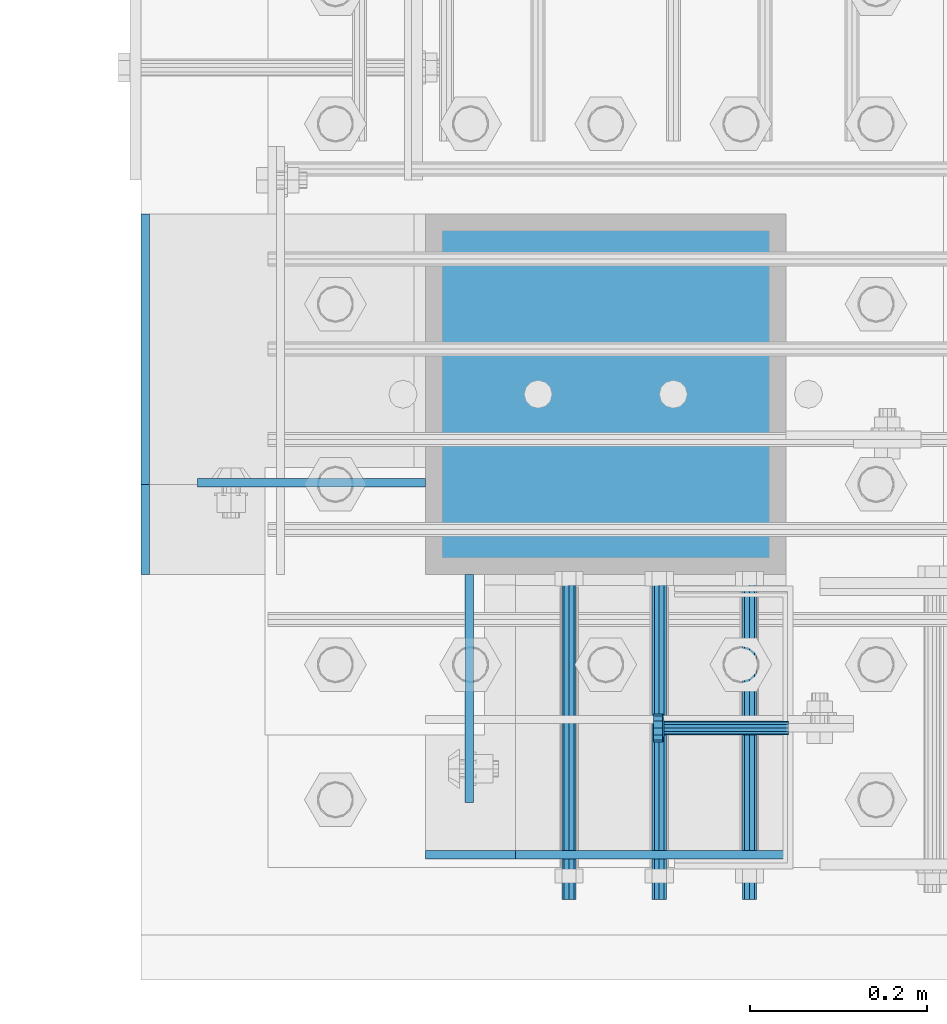
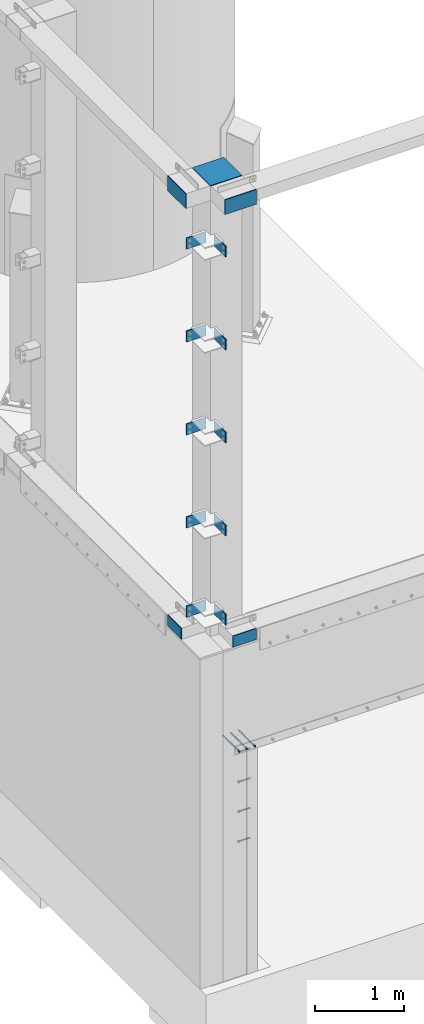
# One storey, part 1080 of 1876: 22 beams, 5 elements without a shape of their own.
"""IFC2X3 building model written with IfcOpenShell, lengths in millimetres."""

from ifc_helpers import new_model, si_unit, frame, origin_with_axes, place, context, subcontext, project, spatial, faceted_brep, material, type_object, element, aggregate, save


model = new_model("IFC2X3")

# Units and contexts
model_context = context("Model", 3, precision=1e-05, world=origin_with_axes())
body_context = subcontext(model_context, "Body", "Model", "MODEL_VIEW")
ifc_project = project(units=[si_unit("LENGTHUNIT", "METRE", prefix="MILLI"), si_unit("AREAUNIT", "SQUARE_METRE"), si_unit("VOLUMEUNIT", "CUBIC_METRE"), si_unit("MASSUNIT", "GRAM", prefix="KILO"), si_unit("TIMEUNIT", "SECOND"), si_unit("PLANEANGLEUNIT", "RADIAN"), si_unit("SOLIDANGLEUNIT", "STERADIAN"), si_unit("THERMODYNAMICTEMPERATUREUNIT", "DEGREE_CELSIUS"), si_unit("LUMINOUSINTENSITYUNIT", "LUMEN")], contexts=[model_context])

# Site, building, storey
site_placement = place(None, origin_with_axes())
site = spatial("IfcSite", under=ifc_project, at=site_placement, CompositionType="ELEMENT")
building_placement = place(site_placement, origin_with_axes())
building = spatial("IfcBuilding", under=site, at=building_placement, Name="Undefined", CompositionType="ELEMENT")
storey_placement = place(building_placement, origin_with_axes())
storey = spatial("IfcBuildingStorey", under=building, at=storey_placement, Name="Undefined", CompositionType="ELEMENT", Elevation=0.0)

# Assembly, beams
assembly_1_placement = place(storey_placement, origin_with_axes())
assembly_1 = element("IfcElementAssembly", 1, at=assembly_1_placement, inside=storey, Name="COLUMN", AssemblyPlace="NOTDEFINED", PredefinedType="RIGID_FRAME")
ifc_material_1 = material(Name="STEEL/A36")
beam_type_1 = type_object("IfcBeamType", PredefinedType="NOTDEFINED")
beam_1_placement = place(assembly_1_placement, frame((77.7874999999989, -25603.2, 4878.3875), z_axis=(0.0, 0.0, -1.0), x_axis=(0.0, -1.0, 0.0)))
beam_1 = element("IfcBeam", 2, at=beam_1_placement, type_object=beam_type_1, material=ifc_material_1, Name="PLATE", context=body_context, shape_type="Brep", body=[
    faceted_brep([(0.0, 4.76249999999982, -76.1999999999998), (3.63797880709171e-12, 4.76249999999982, 76.1999969482422), (257.174999999999, 4.76249999999982, 76.1999999999998), (257.174999999999, 4.76249999999982, -76.1999999999998), (3.63797880709171e-12, -4.76249999999982, 76.1999969482422), (257.174999999999, -4.76249999999982, 76.1999999999998), (0.0, -4.76249999999982, -76.1999999999998), (257.174999999999, -4.76249999999982, -76.1999999999998)], [[[0, 1, 2, 3]], [[1, 4, 5, 2]], [[4, 6, 7, 5]], [[6, 0, 3, 7]], [[5, 7, 3, 2]], [[6, 4, 1, 0]]]),
])
beam_2_placement = place(assembly_1_placement, frame((28.5750000000013, -25500.0124984741, 4878.38749999999), z_axis=(0.0, 0.0, -1.0), x_axis=(-1.0, 0.0, 0.0)))
beam_2 = element("IfcBeam", 3, at=beam_2_placement, type_object=beam_type_1, material=ifc_material_1, Name="PLATE", context=body_context, shape_type="Brep", body=[
    faceted_brep([(0.0, 4.76249999999982, -76.1999999999998), (3.63797880709171e-12, 4.76249999999982, 76.1999969482422), (257.174999999999, 4.76249999999982, 76.1999999999998), (257.174999999999, 4.76249999999982, -76.1999999999998), (3.63797880709171e-12, -4.76249999999982, 76.1999969482422), (257.174999999999, -4.76249999999982, 76.1999999999998), (0.0, -4.76249999999982, -76.1999999999998), (257.174999999999, -4.76249999999982, -76.1999999999998)], [[[0, 1, 2, 3]], [[1, 4, 5, 2]], [[4, 6, 7, 5]], [[6, 0, 3, 7]], [[5, 7, 3, 2]], [[6, 4, 1, 0]]]),
])
beam_3_placement = place(assembly_1_placement, frame((77.787499999998, -25603.2, 9904.41249999999), z_axis=(0.0, 0.0, -1.0), x_axis=(0.0, -1.0, 0.0)))
beam_3 = element("IfcBeam", 4, at=beam_3_placement, type_object=beam_type_1, material=ifc_material_1, Name="PLATE", context=body_context, shape_type="Brep", body=[
    faceted_brep([(0.0, 4.76249999999982, -76.1999999999998), (3.63797880709171e-12, 4.76249999999982, 76.1999969482422), (257.174999999999, 4.76249999999982, 76.1999999999998), (257.174999999999, 4.76249999999982, -76.1999999999998), (3.63797880709171e-12, -4.76249999999982, 76.1999969482422), (257.174999999999, -4.76249999999982, 76.1999999999998), (0.0, -4.76249999999982, -76.1999999999998), (257.174999999999, -4.76249999999982, -76.1999999999998)], [[[0, 1, 2, 3]], [[1, 4, 5, 2]], [[4, 6, 7, 5]], [[6, 0, 3, 7]], [[5, 7, 3, 2]], [[6, 4, 1, 0]]]),
])
beam_4_placement = place(assembly_1_placement, frame((77.7874999999989, -25603.2, 8635.47083333333), z_axis=(0.0, 0.0, -1.0), x_axis=(0.0, -1.0, 0.0)))
beam_4 = element("IfcBeam", 5, at=beam_4_placement, type_object=beam_type_1, material=ifc_material_1, Name="PLATE", context=body_context, shape_type="Brep", body=[
    faceted_brep([(0.0, 4.76249999999982, -76.1999999999998), (3.63797880709171e-12, 4.76249999999982, 76.1999969482422), (257.174999999999, 4.76249999999982, 76.1999999999998), (257.174999999999, 4.76249999999982, -76.1999999999998), (3.63797880709171e-12, -4.76249999999982, 76.1999969482422), (257.174999999999, -4.76249999999982, 76.1999999999998), (0.0, -4.76249999999982, -76.1999999999998), (257.174999999999, -4.76249999999982, -76.1999999999998)], [[[0, 1, 2, 3]], [[1, 4, 5, 2]], [[4, 6, 7, 5]], [[6, 0, 3, 7]], [[5, 7, 3, 2]], [[6, 4, 1, 0]]]),
])
beam_5_placement = place(assembly_1_placement, frame((77.7874999999989, -25603.2, 7366.52916666666), z_axis=(0.0, 0.0, -1.0), x_axis=(0.0, -1.0, 0.0)))
beam_5 = element("IfcBeam", 6, at=beam_5_placement, type_object=beam_type_1, material=ifc_material_1, Name="PLATE", context=body_context, shape_type="Brep", body=[
    faceted_brep([(0.0, 4.76249999999982, -76.1999999999998), (3.63797880709171e-12, 4.76249999999982, 76.1999969482422), (257.174999999999, 4.76249999999982, 76.1999999999998), (257.174999999999, 4.76249999999982, -76.1999999999998), (3.63797880709171e-12, -4.76249999999982, 76.1999969482422), (257.174999999999, -4.76249999999982, 76.1999999999998), (0.0, -4.76249999999982, -76.1999999999998), (257.174999999999, -4.76249999999982, -76.1999999999998)], [[[0, 1, 2, 3]], [[1, 4, 5, 2]], [[4, 6, 7, 5]], [[6, 0, 3, 7]], [[5, 7, 3, 2]], [[6, 4, 1, 0]]]),
])
beam_6_placement = place(assembly_1_placement, frame((77.7874999999989, -25603.2, 6097.5875), z_axis=(0.0, 0.0, -1.0), x_axis=(0.0, -1.0, 0.0)))
beam_6 = element("IfcBeam", 7, at=beam_6_placement, type_object=beam_type_1, material=ifc_material_1, Name="PLATE", context=body_context, shape_type="Brep", body=[
    faceted_brep([(0.0, 4.76249999999982, -76.1999999999998), (3.63797880709171e-12, 4.76249999999982, 76.1999969482422), (257.174999999999, 4.76249999999982, 76.1999999999998), (257.174999999999, 4.76249999999982, -76.1999999999998), (3.63797880709171e-12, -4.76249999999982, 76.1999969482422), (257.174999999999, -4.76249999999982, 76.1999999999998), (0.0, -4.76249999999982, -76.1999999999998), (257.174999999999, -4.76249999999982, -76.1999999999998)], [[[0, 1, 2, 3]], [[1, 4, 5, 2]], [[4, 6, 7, 5]], [[6, 0, 3, 7]], [[5, 7, 3, 2]], [[6, 4, 1, 0]]]),
])
beam_7_placement = place(assembly_1_placement, frame((28.5750000000013, -25500.0124984741, 9904.41249999999), z_axis=(0.0, 0.0, -1.0), x_axis=(-1.0, 0.0, 0.0)))
beam_7 = element("IfcBeam", 8, at=beam_7_placement, type_object=beam_type_1, material=ifc_material_1, Name="PLATE", context=body_context, shape_type="Brep", body=[
    faceted_brep([(0.0, 4.76249999999982, -76.1999999999998), (3.63797880709171e-12, 4.76249999999982, 76.1999969482422), (257.174999999999, 4.76249999999982, 76.1999999999998), (257.174999999999, 4.76249999999982, -76.1999999999998), (3.63797880709171e-12, -4.76249999999982, 76.1999969482422), (257.174999999999, -4.76249999999982, 76.1999999999998), (0.0, -4.76249999999982, -76.1999999999998), (257.174999999999, -4.76249999999982, -76.1999999999998)], [[[0, 1, 2, 3]], [[1, 4, 5, 2]], [[4, 6, 7, 5]], [[6, 0, 3, 7]], [[5, 7, 3, 2]], [[6, 4, 1, 0]]]),
])
beam_8_placement = place(assembly_1_placement, frame((28.5750000000013, -25500.0124984741, 8635.47083333333), z_axis=(0.0, 0.0, -1.0), x_axis=(-1.0, 0.0, 0.0)))
beam_8 = element("IfcBeam", 9, at=beam_8_placement, type_object=beam_type_1, material=ifc_material_1, Name="PLATE", context=body_context, shape_type="Brep", body=[
    faceted_brep([(0.0, 4.76249999999982, -76.1999999999998), (3.63797880709171e-12, 4.76249999999982, 76.1999969482422), (257.174999999999, 4.76249999999982, 76.1999999999998), (257.174999999999, 4.76249999999982, -76.1999999999998), (3.63797880709171e-12, -4.76249999999982, 76.1999969482422), (257.174999999999, -4.76249999999982, 76.1999999999998), (0.0, -4.76249999999982, -76.1999999999998), (257.174999999999, -4.76249999999982, -76.1999999999998)], [[[0, 1, 2, 3]], [[1, 4, 5, 2]], [[4, 6, 7, 5]], [[6, 0, 3, 7]], [[5, 7, 3, 2]], [[6, 4, 1, 0]]]),
])
beam_9_placement = place(assembly_1_placement, frame((28.5750000000013, -25500.0124984741, 7366.46302033333), z_axis=(0.0, 0.0, -1.0), x_axis=(-1.0, 0.0, 0.0)))
beam_9 = element("IfcBeam", 10, at=beam_9_placement, type_object=beam_type_1, material=ifc_material_1, Name="PLATE", context=body_context, shape_type="Brep", body=[
    faceted_brep([(0.0, 4.76249999999982, -76.1999999999998), (3.63797880709171e-12, 4.76249999999982, 76.1999969482422), (257.174999999999, 4.76249999999982, 76.1999999999998), (257.174999999999, 4.76249999999982, -76.1999999999998), (3.63797880709171e-12, -4.76249999999982, 76.1999969482422), (257.174999999999, -4.76249999999982, 76.1999999999998), (0.0, -4.76249999999982, -76.1999999999998), (257.174999999999, -4.76249999999982, -76.1999999999998)], [[[0, 1, 2, 3]], [[1, 4, 5, 2]], [[4, 6, 7, 5]], [[6, 0, 3, 7]], [[5, 7, 3, 2]], [[6, 4, 1, 0]]]),
])
beam_10_placement = place(assembly_1_placement, frame((28.5750000000013, -25500.0124984741, 6097.58749999999), z_axis=(0.0, 0.0, -1.0), x_axis=(-1.0, 0.0, 0.0)))
beam_10 = element("IfcBeam", 11, at=beam_10_placement, type_object=beam_type_1, material=ifc_material_1, Name="PLATE", context=body_context, shape_type="Brep", body=[
    faceted_brep([(0.0, 4.76249999999982, -76.1999999999998), (3.63797880709171e-12, 4.76249999999982, 76.1999969482422), (257.174999999999, 4.76249999999982, 76.1999999999998), (257.174999999999, 4.76249999999982, -76.1999999999998), (3.63797880709171e-12, -4.76249999999982, 76.1999969482422), (257.174999999999, -4.76249999999982, 76.1999999999998), (0.0, -4.76249999999982, -76.1999999999998), (257.174999999999, -4.76249999999982, -76.1999999999998)], [[[0, 1, 2, 3]], [[1, 4, 5, 2]], [[4, 6, 7, 5]], [[6, 0, 3, 7]], [[5, 7, 3, 2]], [[6, 4, 1, 0]]]),
])
beam_11_placement = place(assembly_1_placement, frame((434.974999999999, -25919.1125, 4597.4), z_axis=(0.0, 0.0, 1.0), x_axis=(-1.0, 0.0, 0.0)))
beam_11 = element("IfcBeam", 12, at=beam_11_placement, type_object=beam_type_1, material=ifc_material_1, Name="PLATE", context=body_context, shape_type="Brep", body=[
    faceted_brep([(0.0, 4.76249999999982, -76.1999999999998), (3.63797880709171e-12, 4.76249999999982, 76.1999969482422), (304.799999999999, 4.76250000000073, 76.1999999999998), (304.799999999999, 4.76250000000073, -76.1999999999998), (3.63797880709171e-12, -4.76249999999982, 76.1999969482422), (304.799999999999, -4.76250000000073, 76.1999999999998), (0.0, -4.76249999999982, -76.1999999999998), (304.799999999999, -4.76250000000073, -76.1999999999998)], [[[0, 1, 2, 3]], [[1, 4, 5, 2]], [[4, 6, 7, 5]], [[6, 0, 3, 7]], [[5, 7, 3, 2]], [[6, 4, 1, 0]]]),
])
beam_12_placement = place(assembly_1_placement, frame((-287.337500000009, -25501.6, 4597.4), z_axis=(0.0, 0.0, 1.0), x_axis=(0.0, 1.0, 0.0)))
beam_12 = element("IfcBeam", 13, at=beam_12_placement, type_object=beam_type_1, material=ifc_material_1, Name="PLATE", context=body_context, shape_type="Brep", body=[
    faceted_brep([(0.0, 4.76249999999982, -76.1999999999998), (3.63797880709171e-12, 4.76249999999982, 76.1999969482422), (304.799999999999, 4.76250000000073, 76.1999999999998), (304.799999999999, 4.76250000000073, -76.1999999999998), (3.63797880709171e-12, -4.76249999999982, 76.1999969482422), (304.799999999999, -4.76250000000073, 76.1999999999998), (0.0, -4.76249999999982, -76.1999999999998), (304.799999999999, -4.76250000000073, -76.1999999999998)], [[[0, 1, 2, 3]], [[1, 4, 5, 2]], [[4, 6, 7, 5]], [[6, 0, 3, 7]], [[5, 7, 3, 2]], [[6, 4, 1, 0]]]),
])

# Assembly, beam
assembly_2_placement = place(storey_placement, origin_with_axes())
assembly_2 = element("IfcElementAssembly", 14, at=assembly_2_placement, inside=storey, Name="ANCHOR_BOLT", AssemblyPlace="NOTDEFINED", PredefinedType="RIGID_FRAME")
beam_type_2 = type_object("IfcBeamType", PredefinedType="NOTDEFINED")
beam_13_placement = place(assembly_2_placement, frame((393.700977061869, -25969.9124996982, 3103.56250152592), z_axis=(0.0, 0.0, 1.0), x_axis=(-2.91149999876944e-05, 0.999999999576158, 0.0)))
beam_13 = element("IfcBeam", 15, at=beam_13_placement, type_object=beam_type_2, material=ifc_material_1, Name="ANCHOR_BOLT", context=body_context, shape_type="Brep", body=[
    faceted_brep([(0.0, -7.9375, 0.0), (0.0, -5.61266007566822, -5.61266007566883), (369.887490732475, -5.61266007567792, -5.61266007566837), (369.887490732477, -7.93750000000978, 0.0), (0.0, 0.0, -7.9375), (369.88749073247, -9.54969436861575e-12, -7.9375), (0.0, 5.61266007566822, -5.61266007566883), (369.887490732464, 5.6126600756586, -5.61266007566837), (0.0, 7.9375, 0.0), (369.887490732463, 7.93749999999045, 0.0), (0.0, 5.61266007566822, 5.61266007566883), (369.887490732464, 5.6126600756586, 5.61266007566837), (0.0, 0.0, 7.9375), (369.88749073247, -9.54969436861575e-12, 7.9375), (0.0, -5.61266007566822, 5.61266007566883), (369.887490732475, -5.61266007567792, 5.61266007566837)], [[[0, 1, 2, 3]], [[1, 4, 5, 2]], [[4, 6, 7, 5]], [[6, 8, 9, 7]], [[8, 10, 11, 9]], [[10, 12, 13, 11]], [[12, 14, 15, 13]], [[14, 0, 3, 15]], [[5, 7, 9, 11, 13, 15, 3, 2]], [[14, 12, 10, 8, 6, 4, 1, 0]]]),
])
aggregate(assembly_2, [beam_13])

assembly_3_placement = place(storey_placement, origin_with_axes())
assembly_3 = element("IfcElementAssembly", 16, at=assembly_3_placement, inside=storey, Name="ANCHOR_BOLT", AssemblyPlace="NOTDEFINED", PredefinedType="RIGID_FRAME")
beam_14_placement = place(assembly_3_placement, frame((292.100977061869, -25969.9124996982, 3103.56250152592), z_axis=(0.0, 0.0, 1.0), x_axis=(-2.91149999876944e-05, 0.999999999576158, 0.0)))
beam_14 = element("IfcBeam", 17, at=beam_14_placement, type_object=beam_type_2, material=ifc_material_1, Name="ANCHOR_BOLT", context=body_context, shape_type="Brep", body=[
    faceted_brep([(0.0, -7.9375, 0.0), (0.0, -5.61266007566822, -5.61266007566883), (369.887490732475, -5.61266007567792, -5.61266007566837), (369.887490732477, -7.93750000000978, 0.0), (0.0, 0.0, -7.9375), (369.88749073247, -9.54969436861575e-12, -7.9375), (0.0, 5.61266007566822, -5.61266007566883), (369.887490732464, 5.6126600756586, -5.61266007566837), (0.0, 7.9375, 0.0), (369.887490732463, 7.93749999999045, 0.0), (0.0, 5.61266007566822, 5.61266007566883), (369.887490732464, 5.6126600756586, 5.61266007566837), (0.0, 0.0, 7.9375), (369.88749073247, -9.54969436861575e-12, 7.9375), (0.0, -5.61266007566822, 5.61266007566883), (369.887490732475, -5.61266007567792, 5.61266007566837)], [[[0, 1, 2, 3]], [[1, 4, 5, 2]], [[4, 6, 7, 5]], [[6, 8, 9, 7]], [[8, 10, 11, 9]], [[10, 12, 13, 11]], [[12, 14, 15, 13]], [[14, 0, 3, 15]], [[5, 7, 9, 11, 13, 15, 3, 2]], [[14, 12, 10, 8, 6, 4, 1, 0]]]),
])
aggregate(assembly_3, [beam_14])

assembly_4_placement = place(storey_placement, origin_with_axes())
assembly_4 = element("IfcElementAssembly", 18, at=assembly_4_placement, inside=storey, Name="ANCHOR_BOLT", AssemblyPlace="NOTDEFINED", PredefinedType="RIGID_FRAME")
beam_15_placement = place(assembly_4_placement, frame((190.500977061869, -25969.9124996982, 3103.56250152592), z_axis=(0.0, 0.0, 1.0), x_axis=(-2.91149999876944e-05, 0.999999999576158, 0.0)))
beam_15 = element("IfcBeam", 19, at=beam_15_placement, type_object=beam_type_2, material=ifc_material_1, Name="ANCHOR_BOLT", context=body_context, shape_type="Brep", body=[
    faceted_brep([(0.0, -7.9375, 0.0), (0.0, -5.61266007566822, -5.61266007566883), (369.887490732475, -5.61266007567792, -5.61266007566837), (369.887490732477, -7.93750000000978, 0.0), (0.0, 0.0, -7.9375), (369.88749073247, -9.54969436861575e-12, -7.9375), (0.0, 5.61266007566822, -5.61266007566883), (369.887490732464, 5.6126600756586, -5.61266007566837), (0.0, 7.9375, 0.0), (369.887490732463, 7.93749999999045, 0.0), (0.0, 5.61266007566822, 5.61266007566883), (369.887490732464, 5.6126600756586, 5.61266007566837), (0.0, 0.0, 7.9375), (369.88749073247, -9.54969436861575e-12, 7.9375), (0.0, -5.61266007566822, 5.61266007566883), (369.887490732475, -5.61266007567792, 5.61266007566837)], [[[0, 1, 2, 3]], [[1, 4, 5, 2]], [[4, 6, 7, 5]], [[6, 8, 9, 7]], [[8, 10, 11, 9]], [[10, 12, 13, 11]], [[12, 14, 15, 13]], [[14, 0, 3, 15]], [[5, 7, 9, 11, 13, 15, 3, 2]], [[14, 12, 10, 8, 6, 4, 1, 0]]]),
])
aggregate(assembly_4, [beam_15])

# Beam
beam_type_3 = type_object("IfcBeamType", PredefinedType="NOTDEFINED")
beam_16_placement = place(assembly_1_placement, frame((434.974999999999, -25400.0, 10663.2375), z_axis=(0.0, 1.0, 0.0), x_axis=(-1.0, 0.0, 0.0)))
beam_16 = element("IfcBeam", 20, at=beam_16_placement, type_object=beam_type_3, material=ifc_material_1, Name="PLATE", context=body_context, shape_type="Brep", body=[
    faceted_brep([(0.0, 4.76250000000073, -203.200000000001), (0.0, 4.76250000000073, 203.200000000001), (406.4, 4.76250000000073, 203.200000000001), (406.4, 4.76250000000073, -203.200000000001), (0.0, -4.76250000000073, 203.200000000001), (406.4, -4.76250000000073, 203.200000000001), (0.0, -4.76250000000073, -203.200000000001), (406.4, -4.76250000000073, -203.200000000001)], [[[0, 1, 2, 3]], [[1, 4, 5, 2]], [[4, 6, 7, 5]], [[6, 0, 3, 7]], [[5, 7, 3, 2]], [[6, 4, 1, 0]]]),
])

beam_type_4 = type_object("IfcBeamType", PredefinedType="NOTDEFINED")
beam_17_placement = place(assembly_1_placement, frame((434.974999999999, -25919.1125, 10566.4), z_axis=(0.0, 0.0, 1.0), x_axis=(-1.0, 0.0, 0.0)))
beam_17 = element("IfcBeam", 21, at=beam_17_placement, type_object=beam_type_4, material=ifc_material_1, Name="PLATE", context=body_context, shape_type="Brep", body=[
    faceted_brep([(0.0, 4.76250000000073, -101.6), (-2.38742359215394e-12, 4.76249999999982, 101.599998474137), (406.4, 4.76250000000073, 101.6), (406.4, 4.76250000000073, -101.6), (-2.38742359215394e-12, -4.76249999999982, 101.599998474137), (406.4, -4.76250000000073, 101.6), (0.0, -4.76250000000073, -101.6), (406.4, -4.76250000000073, -101.6)], [[[0, 1, 2, 3]], [[1, 4, 5, 2]], [[4, 6, 7, 5]], [[6, 0, 3, 7]], [[5, 7, 3, 2]], [[6, 4, 1, 0]]]),
])

beam_18_placement = place(assembly_1_placement, frame((-287.337500000009, -25603.2, 10566.4), z_axis=(0.0, 0.0, 1.0), x_axis=(0.0, 1.0, 0.0)))
beam_18 = element("IfcBeam", 22, at=beam_18_placement, type_object=beam_type_4, material=ifc_material_1, Name="PLATE", context=body_context, shape_type="Brep", body=[
    faceted_brep([(0.0, 4.76250000000073, -101.6), (-2.38742359215394e-12, 4.76249999999982, 101.599998474137), (406.4, 4.76250000000073, 101.6), (406.4, 4.76250000000073, -101.6), (-2.38742359215394e-12, -4.76249999999982, 101.599998474137), (406.4, -4.76250000000073, 101.6), (0.0, -4.76250000000073, -101.6), (406.4, -4.76250000000073, -101.6)], [[[0, 1, 2, 3]], [[1, 4, 5, 2]], [[4, 6, 7, 5]], [[6, 0, 3, 7]], [[5, 7, 3, 2]], [[6, 4, 1, 0]]]),
])

aggregate(assembly_1, [beam_1, beam_2, beam_3, beam_4, beam_5, beam_6, beam_7, beam_8, beam_9, beam_10, beam_16, beam_11, beam_12, beam_17, beam_18])

# Assembly, beams
assembly_5_placement = place(storey_placement, origin_with_axes())
assembly_5 = element("IfcElementAssembly", 23, at=assembly_5_placement, inside=storey, Name="BENT PLATE", AssemblyPlace="NOTDEFINED", PredefinedType="RIGID_FRAME")
ifc_material_2 = material(Name="STEEL/A108")
beam_type_5 = type_object("IfcBeamType", Name="STUD_5/8-DIA", PredefinedType="NOTDEFINED")
beam_19_placement = place(assembly_5_placement, frame((437.751629702038, -25776.2375096436, 2946.4), z_axis=(0.0, 0.0, 1.0), x_axis=(-1.0, 0.0, 0.0)))
beam_19 = element("IfcBeam", 24, at=beam_19_placement, type_object=beam_type_5, material=ifc_material_2, Name="WELDED HEADED STUD", ObjectType="STUD_5/8-DIA", context=body_context, shape_type="Brep", body=[
    faceted_brep([(0.0, -7.94000005722046, 0.0), (0.0, -6.86999988555908, -3.97000002861023), (140.207082738083, -6.86999988555908, -3.97000002861023), (140.207082738083, -7.94000005722046, 0.0), (0.0, -3.97000002861023, -6.86999988555908), (140.207082738083, -3.97000002861023, -6.86999988555908), (0.0, 0.0, -7.94000005722046), (140.207082738083, 0.0, -7.94000005722046), (0.0, 3.97000002861023, -6.86999988555908), (140.207082738083, 3.97000002861023, -6.86999988555908), (0.0, 6.86999988555908, -3.97000002861023), (140.207082738083, 6.86999988555908, -3.97000002861023), (0.0, 7.94000005722046, 0.0), (140.207082738083, 7.94000005722046, 0.0), (0.0, 6.86999988555908, 3.97000002861023), (140.207082738083, 6.86999988555908, 3.97000002861023), (0.0, 3.97000002861023, 6.86999988555908), (140.207082738083, 3.97000002861023, 6.86999988555908), (0.0, 0.0, 7.94000005722046), (140.207082738083, 0.0, 7.94000005722046), (0.0, -3.97000002861023, 6.86999988555908), (140.207082738083, -3.97000002861023, 6.86999988555908), (0.0, -6.86999988555908, 3.97000002861023), (140.207082738083, -6.86999988555908, 3.97000002861023), (141.731072767845, -13.75, -7.94000005722046), (141.731072767845, -15.8800001144409, 0.0), (141.731072767845, -7.94000005722046, -13.75), (141.731072767845, 0.0, -15.8800001144409), (141.731072767845, 7.94000005722046, -13.75), (141.731072767845, 13.75, -7.94000005722046), (141.731072767845, 15.8800001144409, 0.0), (141.731072767845, 13.75, 7.94000005722046), (141.731072767845, 7.94000005722046, 13.75), (141.731072767845, 0.0, 15.8800001144409), (141.731072767845, -7.94000005722046, 13.75), (141.731072767845, -13.75, 7.94000005722046), (152.399002976177, -13.75, -7.94000005722046), (152.399002976177, -15.8800001144409, 0.0), (152.399002976177, -7.94000005722046, -13.75), (152.399002976177, 0.0, -15.8800001144409), (152.399002976177, 7.94000005722046, -13.75), (152.399002976177, 13.75, -7.94000005722046), (152.399002976177, 15.8800001144409, 0.0), (152.399002976177, 13.75, 7.94000005722046), (152.399002976177, 7.94000005722046, 13.75), (152.399002976177, 0.0, 15.8800001144409), (152.399002976177, -7.94000005722046, 13.75), (152.399002976177, -13.75, 7.94000005722046)], [[[0, 1, 2, 3]], [[1, 4, 5, 2]], [[4, 6, 7, 5]], [[6, 8, 9, 7]], [[8, 10, 11, 9]], [[10, 12, 13, 11]], [[12, 14, 15, 13]], [[14, 16, 17, 15]], [[16, 18, 19, 17]], [[18, 20, 21, 19]], [[20, 22, 23, 21]], [[22, 0, 3, 23]], [[22, 20, 18, 16, 14, 12, 10, 8, 6, 4, 1, 0]], [[3, 2, 24, 25]], [[2, 5, 26, 24]], [[5, 7, 27, 26]], [[7, 9, 28, 27]], [[9, 11, 29, 28]], [[11, 13, 30, 29]], [[13, 15, 31, 30]], [[15, 17, 32, 31]], [[17, 19, 33, 32]], [[19, 21, 34, 33]], [[21, 23, 35, 34]], [[23, 3, 25, 35]], [[25, 24, 36, 37]], [[24, 26, 38, 36]], [[26, 27, 39, 38]], [[27, 28, 40, 39]], [[28, 29, 41, 40]], [[29, 30, 42, 41]], [[30, 31, 43, 42]], [[31, 32, 44, 43]], [[32, 33, 45, 44]], [[33, 34, 46, 45]], [[34, 35, 47, 46]], [[35, 25, 37, 47]], [[38, 39, 40, 41, 42, 43, 44, 45, 46, 47, 37, 36]]]),
])
beam_20_placement = place(assembly_5_placement, frame((437.751629702038, -25776.2375096436, 2540.0), z_axis=(0.0, 0.0, 1.0), x_axis=(-1.0, 0.0, 0.0)))
beam_20 = element("IfcBeam", 25, at=beam_20_placement, type_object=beam_type_5, material=ifc_material_2, Name="WELDED HEADED STUD", ObjectType="STUD_5/8-DIA", context=body_context, shape_type="Brep", body=[
    faceted_brep([(0.0, -7.94000005722046, 0.0), (0.0, -6.86999988555908, -3.97000002861023), (140.207082738083, -6.86999988555908, -3.97000002861023), (140.207082738083, -7.94000005722046, 0.0), (0.0, -3.97000002861023, -6.86999988555908), (140.207082738083, -3.97000002861023, -6.86999988555908), (0.0, 0.0, -7.94000005722046), (140.207082738083, 0.0, -7.94000005722046), (0.0, 3.97000002861023, -6.86999988555908), (140.207082738083, 3.97000002861023, -6.86999988555908), (0.0, 6.86999988555908, -3.97000002861023), (140.207082738083, 6.86999988555908, -3.97000002861023), (0.0, 7.94000005722046, 0.0), (140.207082738083, 7.94000005722046, 0.0), (0.0, 6.86999988555908, 3.97000002861023), (140.207082738083, 6.86999988555908, 3.97000002861023), (0.0, 3.97000002861023, 6.86999988555908), (140.207082738083, 3.97000002861023, 6.86999988555908), (0.0, 0.0, 7.94000005722046), (140.207082738083, 0.0, 7.94000005722046), (0.0, -3.97000002861023, 6.86999988555908), (140.207082738083, -3.97000002861023, 6.86999988555908), (0.0, -6.86999988555908, 3.97000002861023), (140.207082738083, -6.86999988555908, 3.97000002861023), (141.731072767845, -13.75, -7.94000005722046), (141.731072767845, -15.8800001144409, 0.0), (141.731072767845, -7.94000005722046, -13.75), (141.731072767845, 0.0, -15.8800001144409), (141.731072767845, 7.94000005722046, -13.75), (141.731072767845, 13.75, -7.94000005722046), (141.731072767845, 15.8800001144409, 0.0), (141.731072767845, 13.75, 7.94000005722046), (141.731072767845, 7.94000005722046, 13.75), (141.731072767845, 0.0, 15.8800001144409), (141.731072767845, -7.94000005722046, 13.75), (141.731072767845, -13.75, 7.94000005722046), (152.399002976177, -13.75, -7.94000005722046), (152.399002976177, -15.8800001144409, 0.0), (152.399002976177, -7.94000005722046, -13.75), (152.399002976177, 0.0, -15.8800001144409), (152.399002976177, 7.94000005722046, -13.75), (152.399002976177, 13.75, -7.94000005722046), (152.399002976177, 15.8800001144409, 0.0), (152.399002976177, 13.75, 7.94000005722046), (152.399002976177, 7.94000005722046, 13.75), (152.399002976177, 0.0, 15.8800001144409), (152.399002976177, -7.94000005722046, 13.75), (152.399002976177, -13.75, 7.94000005722046)], [[[0, 1, 2, 3]], [[1, 4, 5, 2]], [[4, 6, 7, 5]], [[6, 8, 9, 7]], [[8, 10, 11, 9]], [[10, 12, 13, 11]], [[12, 14, 15, 13]], [[14, 16, 17, 15]], [[16, 18, 19, 17]], [[18, 20, 21, 19]], [[20, 22, 23, 21]], [[22, 0, 3, 23]], [[22, 20, 18, 16, 14, 12, 10, 8, 6, 4, 1, 0]], [[3, 2, 24, 25]], [[2, 5, 26, 24]], [[5, 7, 27, 26]], [[7, 9, 28, 27]], [[9, 11, 29, 28]], [[11, 13, 30, 29]], [[13, 15, 31, 30]], [[15, 17, 32, 31]], [[17, 19, 33, 32]], [[19, 21, 34, 33]], [[21, 23, 35, 34]], [[23, 3, 25, 35]], [[25, 24, 36, 37]], [[24, 26, 38, 36]], [[26, 27, 39, 38]], [[27, 28, 40, 39]], [[28, 29, 41, 40]], [[29, 30, 42, 41]], [[30, 31, 43, 42]], [[31, 32, 44, 43]], [[32, 33, 45, 44]], [[33, 34, 46, 45]], [[34, 35, 47, 46]], [[35, 25, 37, 47]], [[38, 39, 40, 41, 42, 43, 44, 45, 46, 47, 37, 36]]]),
])
beam_21_placement = place(assembly_5_placement, frame((437.751629702038, -25776.2375096436, 2133.6), z_axis=(0.0, 0.0, 1.0), x_axis=(-1.0, 0.0, 0.0)))
beam_21 = element("IfcBeam", 26, at=beam_21_placement, type_object=beam_type_5, material=ifc_material_2, Name="WELDED HEADED STUD", ObjectType="STUD_5/8-DIA", context=body_context, shape_type="Brep", body=[
    faceted_brep([(0.0, -7.94000005722046, 0.0), (0.0, -6.86999988555908, -3.97000002861023), (140.207082738083, -6.86999988555908, -3.97000002861023), (140.207082738083, -7.94000005722046, 0.0), (0.0, -3.97000002861023, -6.86999988555908), (140.207082738083, -3.97000002861023, -6.86999988555908), (0.0, 0.0, -7.94000005722046), (140.207082738083, 0.0, -7.94000005722046), (0.0, 3.97000002861023, -6.86999988555908), (140.207082738083, 3.97000002861023, -6.86999988555908), (0.0, 6.86999988555908, -3.97000002861023), (140.207082738083, 6.86999988555908, -3.97000002861023), (0.0, 7.94000005722046, 0.0), (140.207082738083, 7.94000005722046, 0.0), (0.0, 6.86999988555908, 3.97000002861023), (140.207082738083, 6.86999988555908, 3.97000002861023), (0.0, 3.97000002861023, 6.86999988555908), (140.207082738083, 3.97000002861023, 6.86999988555908), (0.0, 0.0, 7.94000005722046), (140.207082738083, 0.0, 7.94000005722046), (0.0, -3.97000002861023, 6.86999988555908), (140.207082738083, -3.97000002861023, 6.86999988555908), (0.0, -6.86999988555908, 3.97000002861023), (140.207082738083, -6.86999988555908, 3.97000002861023), (141.731072767845, -13.75, -7.94000005722046), (141.731072767845, -15.8800001144409, 0.0), (141.731072767845, -7.94000005722046, -13.75), (141.731072767845, 0.0, -15.8800001144409), (141.731072767845, 7.94000005722046, -13.75), (141.731072767845, 13.75, -7.94000005722046), (141.731072767845, 15.8800001144409, 0.0), (141.731072767845, 13.75, 7.94000005722046), (141.731072767845, 7.94000005722046, 13.75), (141.731072767845, 0.0, 15.8800001144409), (141.731072767845, -7.94000005722046, 13.75), (141.731072767845, -13.75, 7.94000005722046), (152.399002976177, -13.75, -7.94000005722046), (152.399002976177, -15.8800001144409, 0.0), (152.399002976177, -7.94000005722046, -13.75), (152.399002976177, 0.0, -15.8800001144409), (152.399002976177, 7.94000005722046, -13.75), (152.399002976177, 13.75, -7.94000005722046), (152.399002976177, 15.8800001144409, 0.0), (152.399002976177, 13.75, 7.94000005722046), (152.399002976177, 7.94000005722046, 13.75), (152.399002976177, 0.0, 15.8800001144409), (152.399002976177, -7.94000005722046, 13.75), (152.399002976177, -13.75, 7.94000005722046)], [[[0, 1, 2, 3]], [[1, 4, 5, 2]], [[4, 6, 7, 5]], [[6, 8, 9, 7]], [[8, 10, 11, 9]], [[10, 12, 13, 11]], [[12, 14, 15, 13]], [[14, 16, 17, 15]], [[16, 18, 19, 17]], [[18, 20, 21, 19]], [[20, 22, 23, 21]], [[22, 0, 3, 23]], [[22, 20, 18, 16, 14, 12, 10, 8, 6, 4, 1, 0]], [[3, 2, 24, 25]], [[2, 5, 26, 24]], [[5, 7, 27, 26]], [[7, 9, 28, 27]], [[9, 11, 29, 28]], [[11, 13, 30, 29]], [[13, 15, 31, 30]], [[15, 17, 32, 31]], [[17, 19, 33, 32]], [[19, 21, 34, 33]], [[21, 23, 35, 34]], [[23, 3, 25, 35]], [[25, 24, 36, 37]], [[24, 26, 38, 36]], [[26, 27, 39, 38]], [[27, 28, 40, 39]], [[28, 29, 41, 40]], [[29, 30, 42, 41]], [[30, 31, 43, 42]], [[31, 32, 44, 43]], [[32, 33, 45, 44]], [[33, 34, 46, 45]], [[34, 35, 47, 46]], [[35, 25, 37, 47]], [[38, 39, 40, 41, 42, 43, 44, 45, 46, 47, 37, 36]]]),
])
beam_22_placement = place(assembly_5_placement, frame((437.751629702038, -25776.2375096436, 1727.2), z_axis=(0.0, 0.0, 1.0), x_axis=(-1.0, 0.0, 0.0)))
beam_22 = element("IfcBeam", 27, at=beam_22_placement, type_object=beam_type_5, material=ifc_material_2, Name="WELDED HEADED STUD", ObjectType="STUD_5/8-DIA", context=body_context, shape_type="Brep", body=[
    faceted_brep([(0.0, -7.94000005722046, 0.0), (0.0, -6.86999988555908, -3.97000002861023), (140.207082738083, -6.86999988555908, -3.97000002861023), (140.207082738083, -7.94000005722046, 0.0), (0.0, -3.97000002861023, -6.86999988555908), (140.207082738083, -3.97000002861023, -6.86999988555908), (0.0, 0.0, -7.94000005722046), (140.207082738083, 0.0, -7.94000005722046), (0.0, 3.97000002861023, -6.86999988555908), (140.207082738083, 3.97000002861023, -6.86999988555908), (0.0, 6.86999988555908, -3.97000002861023), (140.207082738083, 6.86999988555908, -3.97000002861023), (0.0, 7.94000005722046, 0.0), (140.207082738083, 7.94000005722046, 0.0), (0.0, 6.86999988555908, 3.97000002861023), (140.207082738083, 6.86999988555908, 3.97000002861023), (0.0, 3.97000002861023, 6.86999988555908), (140.207082738083, 3.97000002861023, 6.86999988555908), (0.0, 0.0, 7.94000005722046), (140.207082738083, 0.0, 7.94000005722046), (0.0, -3.97000002861023, 6.86999988555908), (140.207082738083, -3.97000002861023, 6.86999988555908), (0.0, -6.86999988555908, 3.97000002861023), (140.207082738083, -6.86999988555908, 3.97000002861023), (141.731072767845, -13.75, -7.94000005722046), (141.731072767845, -15.8800001144409, 0.0), (141.731072767845, -7.94000005722046, -13.75), (141.731072767845, 0.0, -15.8800001144409), (141.731072767845, 7.94000005722046, -13.75), (141.731072767845, 13.75, -7.94000005722046), (141.731072767845, 15.8800001144409, 0.0), (141.731072767845, 13.75, 7.94000005722046), (141.731072767845, 7.94000005722046, 13.75), (141.731072767845, 0.0, 15.8800001144409), (141.731072767845, -7.94000005722046, 13.75), (141.731072767845, -13.75, 7.94000005722046), (152.399002976177, -13.75, -7.94000005722046), (152.399002976177, -15.8800001144409, 0.0), (152.399002976177, -7.94000005722046, -13.75), (152.399002976177, 0.0, -15.8800001144409), (152.399002976177, 7.94000005722046, -13.75), (152.399002976177, 13.75, -7.94000005722046), (152.399002976177, 15.8800001144409, 0.0), (152.399002976177, 13.75, 7.94000005722046), (152.399002976177, 7.94000005722046, 13.75), (152.399002976177, 0.0, 15.8800001144409), (152.399002976177, -7.94000005722046, 13.75), (152.399002976177, -13.75, 7.94000005722046)], [[[0, 1, 2, 3]], [[1, 4, 5, 2]], [[4, 6, 7, 5]], [[6, 8, 9, 7]], [[8, 10, 11, 9]], [[10, 12, 13, 11]], [[12, 14, 15, 13]], [[14, 16, 17, 15]], [[16, 18, 19, 17]], [[18, 20, 21, 19]], [[20, 22, 23, 21]], [[22, 0, 3, 23]], [[22, 20, 18, 16, 14, 12, 10, 8, 6, 4, 1, 0]], [[3, 2, 24, 25]], [[2, 5, 26, 24]], [[5, 7, 27, 26]], [[7, 9, 28, 27]], [[9, 11, 29, 28]], [[11, 13, 30, 29]], [[13, 15, 31, 30]], [[15, 17, 32, 31]], [[17, 19, 33, 32]], [[19, 21, 34, 33]], [[21, 23, 35, 34]], [[23, 3, 25, 35]], [[25, 24, 36, 37]], [[24, 26, 38, 36]], [[26, 27, 39, 38]], [[27, 28, 40, 39]], [[28, 29, 41, 40]], [[29, 30, 42, 41]], [[30, 31, 43, 42]], [[31, 32, 44, 43]], [[32, 33, 45, 44]], [[33, 34, 46, 45]], [[34, 35, 47, 46]], [[35, 25, 37, 47]], [[38, 39, 40, 41, 42, 43, 44, 45, 46, 47, 37, 36]]]),
])
aggregate(assembly_5, [beam_19, beam_20, beam_21, beam_22])

save(model, "model.ifc")
